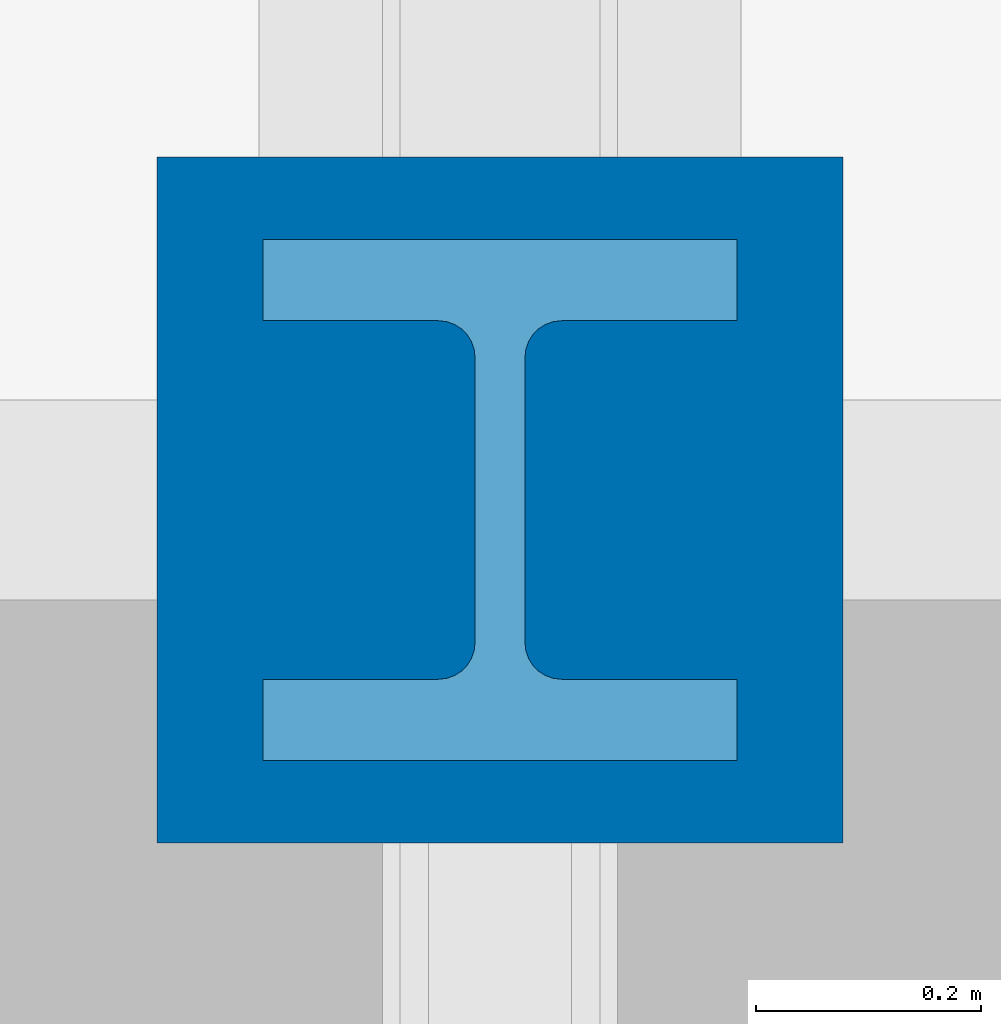
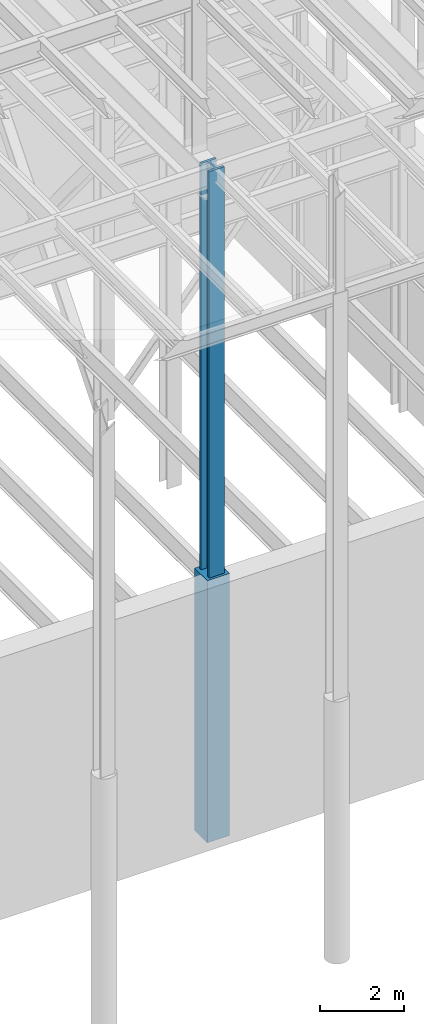
# One storey, part 79 of 150: 2 columns.
"""IFC2X3 building model written with IfcOpenShell, lengths in millimetres."""

from ifc_helpers import new_model, si_unit, frame, origin_with_axes, origin_2d_with_axis, place, context, subcontext, project, spatial, rectangle, i_section, extrude, material, type_object, element, save


model = new_model("IFC2X3")

# Units and contexts
model_context = context("Model", 3, precision=1e-05, world=origin_with_axes())
body_context = subcontext(model_context, "Body", "Model", "MODEL_VIEW")
ifc_project = project(units=[si_unit("LENGTHUNIT", "METRE", prefix="MILLI"), si_unit("AREAUNIT", "SQUARE_METRE"), si_unit("VOLUMEUNIT", "CUBIC_METRE"), si_unit("MASSUNIT", "GRAM", prefix="KILO"), si_unit("TIMEUNIT", "SECOND"), si_unit("PLANEANGLEUNIT", "RADIAN"), si_unit("SOLIDANGLEUNIT", "STERADIAN"), si_unit("THERMODYNAMICTEMPERATUREUNIT", "DEGREE_CELSIUS"), si_unit("LUMINOUSINTENSITYUNIT", "LUMEN")], contexts=[model_context])

# Site, building, storey
site_placement = place(None, origin_with_axes())
site = spatial("IfcSite", under=ifc_project, at=site_placement, CompositionType="ELEMENT")
building_placement = place(site_placement, origin_with_axes())
building = spatial("IfcBuilding", under=site, at=building_placement, Name="Undefined", CompositionType="ELEMENT")
storey_placement = place(building_placement, origin_with_axes())
storey = spatial("IfcBuildingStorey", under=building, at=storey_placement, Name="Undefined", CompositionType="ELEMENT", Elevation=0.0)

# Columns
ifc_material_1 = material(Name="CONCRETE/5000")
column_type_1 = type_object("IfcColumnType", PredefinedType="NOTDEFINED")
column_1_placement = place(storey_placement, frame((75793.6, 9398.0, 16154.4), z_axis=(0.0, 0.0, 1.0), x_axis=(1.0, 0.0, 0.0)))
element("IfcColumn", 1, at=column_1_placement, inside=storey, type_object=column_type_1, material=ifc_material_1, Name="COLUMN", context=body_context, shape_type="SweptSolid", body=[
    extrude(rectangle(XDim=609.6, YDim=609.6, at=origin_2d_with_axis()), frame((0.0, 0.0, 7620.0), z_axis=(0.0, 0.0, -1.0), x_axis=(0.0, -1.0, 0.0)), (0.0, 0.0, 1.0), 7620.0),
])
ifc_material_2 = material(Name="STEEL/A992")
column_type_2 = type_object("IfcColumnType", Name="W14X398", PredefinedType="NOTDEFINED")
column_2_placement = place(storey_placement, frame((75793.6, 9398.0, 22707.6), z_axis=(0.0, 0.0, 1.0), x_axis=(1.0, 0.0, 0.0)))
element("IfcColumn", 2, at=column_2_placement, inside=storey, type_object=column_type_2, material=ifc_material_2, Name="COLUMN", ObjectType="W14X398", context=body_context, shape_type="SweptSolid", body=[
    extrude(i_section(OverallWidth=421.64, OverallDepth=463.55, WebThickness=44.45, FlangeThickness=72.39, FilletRadius=32.512, at=origin_2d_with_axis()), frame((0.0, 0.0, 12877.8), z_axis=(0.0, 0.0, -1.0), x_axis=(-1.0, 0.0, 0.0)), (0.0, 0.0, 1.0), 12877.8),
])

save(model, "model.ifc")
